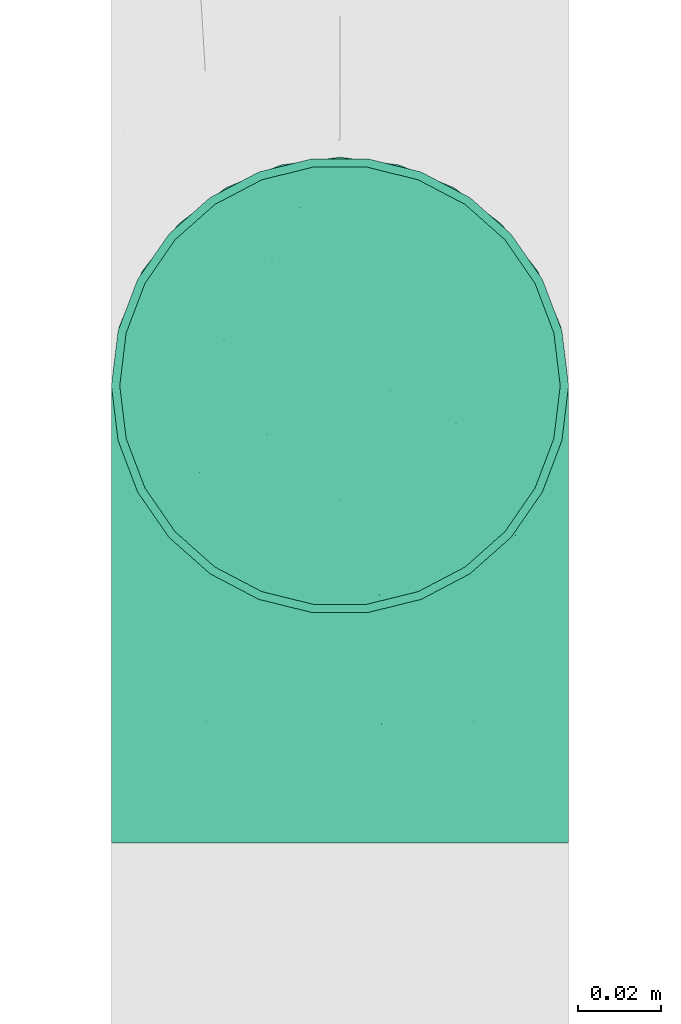
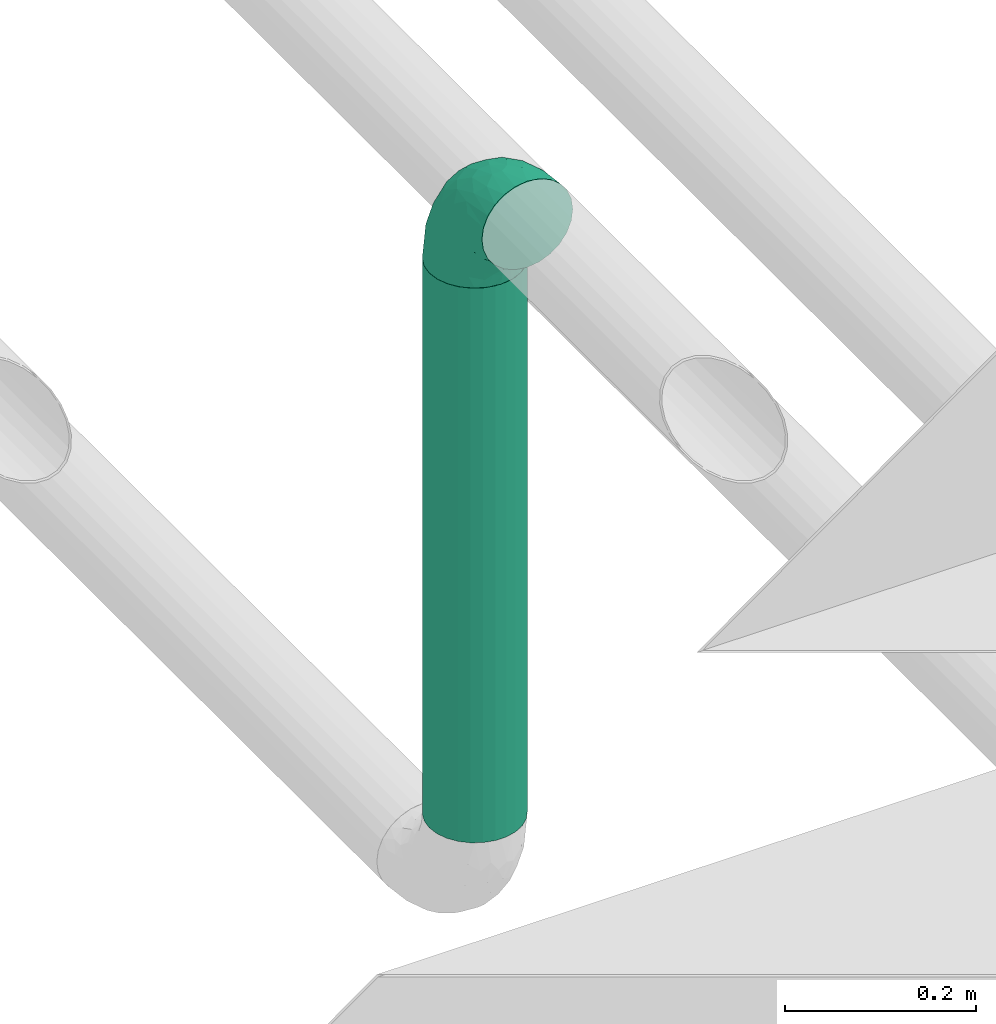
# One storey, part 43 of 91: 1 flow fitting, 1 flow segment.
"""IFC2X3 building model written with IfcOpenShell, lengths in millimetres."""

import ifcopenshell
import ifcopenshell.guid

model = None  # the IFC model being written
_history = None  # IfcOwnerHistory: only IFC2X3 demands one
_inside = {}  # id of a spatial element -> (the spatial element, [elements in it])
_under = {}  # id of a project, library or spatial element -> (it, [spatial elements below it])
_declared = {}  # id of a project -> (the project, [libraries it declares])
_typed = {}  # id of a type object -> (the type object, [elements of that type])
_made_of = {}  # id of a material, layer set ... -> (it, [elements and type objects made of it])


def new_model(schema):
    """Start an empty IFC model of exactly this schema.

    Asked for "IFC4X3", IfcOpenShell would pick the latest addendum, in which some entities
    have other attributes; the version numbers below select the first issue.
    IFC2X3 requires an IfcOwnerHistory on every rooted entity: one is made here for all.
    """
    global model, _history
    if schema == "IFC4X3":
        model = ifcopenshell.file(schema_version=(4, 3, 0, 0))
    else:
        model = ifcopenshell.file(schema=schema)
    _inside.clear()
    _under.clear()
    _declared.clear()
    _typed.clear()
    _made_of.clear()
    _history = None
    if model.schema == "IFC2X3":
        org = make("IfcOrganization", Name="unknown")
        user = make(
            "IfcPersonAndOrganization",
            ThePerson=make("IfcPerson", FamilyName="unknown"),
            TheOrganization=org,
        )
        app = make(
            "IfcApplication",
            ApplicationDeveloper=org,
            Version="unknown",
            ApplicationFullName="unknown",
            ApplicationIdentifier="unknown",
        )
        _history = make(
            "IfcOwnerHistory",
            OwningUser=user,
            OwningApplication=app,
            ChangeAction="ADDED",
            CreationDate=0,
        )
    return model


def make(cls, **values):
    """One entity of the class cls with the attributes given. An attribute that is None is left unset."""
    return model.create_entity(
        cls, **{name: value for name, value in values.items() if value is not None}
    )


def entity(cls, *values):
    """Any entity or typed value of the class cls, its attributes in the order of the schema. None: left unset."""
    e = model.create_entity(cls)
    for i, value in enumerate(values):
        if value is not None:
            e[i] = value
    return e


def rooted(cls, **values):
    """An entity with a GlobalId (a new one), such as an element, a storey or a relation."""
    return make(cls, GlobalId=ifcopenshell.guid.new(), OwnerHistory=_history, **values)


def si_unit(unit_type, name, prefix=None):
    """IfcSIUnit, for example si_unit("LENGTHUNIT", "METRE", prefix="MILLI")."""
    return make("IfcSIUnit", UnitType=unit_type, Prefix=prefix, Name=name)


def converted_unit(unit_type, name, factor, base, dimensions=None, offset=None):
    """IfcConversionBasedUnit, such as the inch: factor (a typed value) times the base unit."""
    return make(
        "IfcConversionBasedUnit"
        if offset is None
        else "IfcConversionBasedUnitWithOffset",
        ConversionOffset=offset,
        Dimensions=None
        if dimensions is None
        else entity("IfcDimensionalExponents", *dimensions),
        UnitType=unit_type,
        Name=name,
        ConversionFactor=make(
            "IfcMeasureWithUnit", ValueComponent=factor, UnitComponent=base
        ),
    )


def derived_unit(unit_type, elements):
    """IfcDerivedUnit: a product of units, each with its exponent."""
    return make(
        "IfcDerivedUnit",
        Elements=[
            make("IfcDerivedUnitElement", Unit=unit, Exponent=power)
            for unit, power in elements
        ],
        UnitType=unit_type,
    )


def assignment(units):
    """IfcUnitAssignment: the units of a project."""
    return None if units is None else make("IfcUnitAssignment", Units=units)


def point(xyz):
    """IfcCartesianPoint."""
    return None if xyz is None else make("IfcCartesianPoint", Coordinates=xyz)


def direction(xyz):
    """IfcDirection."""
    return None if xyz is None else make("IfcDirection", DirectionRatios=xyz)


def frame(location, z_axis=None, x_axis=None):
    """IfcAxis2Placement3D, a coordinate frame: its origin and axes. An axis left out is left unset."""
    return make(
        "IfcAxis2Placement3D",
        Location=point(location),
        Axis=direction(z_axis),
        RefDirection=direction(x_axis),
    )


def frame_2d(location, x_axis=None):
    """IfcAxis2Placement2D, a coordinate frame in the plane: its origin and x axis."""
    return make(
        "IfcAxis2Placement2D", Location=point(location), RefDirection=direction(x_axis)
    )


def origin_with_axes():
    """The frame at (0, 0, 0) with the z axis (0, 0, 1) and the x axis (1, 0, 0) written out."""
    return frame((0.0, 0.0, 0.0), z_axis=(0.0, 0.0, 1.0), x_axis=(1.0, 0.0, 0.0))


def origin_2d_with_axis():
    """The frame at (0, 0) in the plane with the x axis (1, 0) written out."""
    return frame_2d((0.0, 0.0), x_axis=(1.0, 0.0))


def place(relative_to, where):
    """IfcLocalPlacement: puts the frame where relative to a parent placement (None: the world)."""
    return make(
        "IfcLocalPlacement", PlacementRelTo=relative_to, RelativePlacement=where
    )


def context(
    kind, dimensions, precision=None, world=None, true_north=None, identifier=None
):
    """IfcGeometricRepresentationContext, for example the 3D "Model" context."""
    return make(
        "IfcGeometricRepresentationContext",
        ContextIdentifier=identifier,
        ContextType=kind,
        CoordinateSpaceDimension=dimensions,
        Precision=precision,
        WorldCoordinateSystem=world,
        TrueNorth=true_north,
    )


def subcontext(parent, identifier, kind, view, scale=None):
    """IfcGeometricRepresentationSubContext, for example "Body" below "Model"."""
    return make(
        "IfcGeometricRepresentationSubContext",
        ContextIdentifier=identifier,
        ContextType=kind,
        ParentContext=parent,
        TargetScale=scale,
        TargetView=view,
    )


def project(units=None, contexts=None):
    """IfcProject with its units and contexts."""
    return rooted(
        "IfcProject",
        Name="project",
        RepresentationContexts=contexts,
        UnitsInContext=assignment(units),
    )


def spatial(cls, under=None, at=None, **own):
    """A site, building, storey or space (cls), placed at a placement, below another one or the project."""
    s = rooted(cls, ObjectPlacement=at, **own)
    if under is not None:
        _under.setdefault(under.id(), (under, []))[1].append(s)
    return s


def profile(cls, at=None, kind="AREA", **sizes):
    """A parametric profile (cls). Its sizes go by their IFC names, for example OverallWidth=200.0."""
    return make(cls, ProfileType=kind, Position=at, **sizes)


def hollow_circle(**sizes):
    """IfcCircleHollowProfileDef."""
    return profile("IfcCircleHollowProfileDef", **sizes)


def extrude(swept, where, along, depth):
    """IfcExtrudedAreaSolid: the profile swept, set in the frame where, extruded along a direction by depth."""
    return make(
        "IfcExtrudedAreaSolid",
        SweptArea=swept,
        Position=where,
        ExtrudedDirection=direction(along),
        Depth=depth,
    )


def faces_of(points, faces, orient=None, outer=None):
    """IfcFace entities. A face is a list of loops; a loop is a list of indices into points, from 0.

    orient and outer hold one flag for each loop. By default every Orientation is true, the
    first loop of a face is its IfcFaceOuterBound and the others are IfcFaceBound.
    """
    made = []
    for i, loops in enumerate(faces):
        bounds = []
        for j, loop in enumerate(loops):
            is_outer = j == 0 if outer is None else outer[i][j]
            bounds.append(
                make(
                    "IfcFaceOuterBound" if is_outer else "IfcFaceBound",
                    Bound=make("IfcPolyLoop", Polygon=[points[k] for k in loop]),
                    Orientation=True if orient is None else orient[i][j],
                )
            )
        made.append(make("IfcFace", Bounds=bounds))
    return made


def open_shell(faces, orient=None, outer=None):
    """The faces of one IfcOpenShell. surface_model builds it on its shared points."""
    return ("IfcOpenShell", faces, orient, outer)


def surface_model(cls, points, shells):
    """IfcFaceBasedSurfaceModel or IfcShellBasedSurfaceModel (cls): surfaces that need not close."""
    shared = [point(p) for p in points]
    made = [make(c, CfsFaces=faces_of(shared, fs, o, b)) for c, fs, o, b in shells]
    if cls == "IfcFaceBasedSurfaceModel":
        return make(cls, FbsmFaces=made)
    return make(cls, SbsmBoundary=made)


def shape(context_of_items, identifier, shape_type, items):
    """IfcShapeRepresentation: the items that make up one representation, for example the "Body"."""
    return make(
        "IfcShapeRepresentation",
        ContextOfItems=context_of_items,
        RepresentationIdentifier=identifier,
        RepresentationType=shape_type,
        Items=items,
    )


def source(mapping_origin, context_of_items, identifier, shape_type, items):
    """IfcRepresentationMap: a shape defined once, which mapped items show again and again."""
    return make(
        "IfcRepresentationMap",
        MappingOrigin=mapping_origin,
        MappedRepresentation=shape(context_of_items, identifier, shape_type, items),
    )


def transform(
    local_origin,
    x_axis=None,
    y_axis=None,
    z_axis=None,
    scale=None,
    scale2=None,
    scale3=None,
    uniform=True,
):
    """IfcCartesianTransformationOperator3D, or its non-uniform kind. x_axis, y_axis, z_axis: its Axis1, 2, 3."""
    if uniform:
        return make(
            "IfcCartesianTransformationOperator3D",
            Axis1=direction(x_axis),
            Axis2=direction(y_axis),
            LocalOrigin=point(local_origin),
            Scale=scale,
            Axis3=direction(z_axis),
        )
    return make(
        "IfcCartesianTransformationOperator3DnonUniform",
        Axis1=direction(x_axis),
        Axis2=direction(y_axis),
        LocalOrigin=point(local_origin),
        Scale=scale,
        Axis3=direction(z_axis),
        Scale2=scale2,
        Scale3=scale3,
    )


def mapped(mapping_source, mapping_target):
    """IfcMappedItem: shows the shape of a source again, moved by a transform."""
    return make(
        "IfcMappedItem", MappingSource=mapping_source, MappingTarget=mapping_target
    )


def material(Name=None, Category=None):
    """IfcMaterial."""
    return make("IfcMaterial", Name=Name, Category=Category)


def layer(
    of_material, thickness, ventilated=None, Name=None, Category=None, Priority=None
):
    """IfcMaterialLayer: one layer of a wall or slab, of a material (None: an air gap)."""
    return make(
        "IfcMaterialLayer",
        Material=of_material,
        LayerThickness=thickness,
        IsVentilated=ventilated,
        Name=Name,
        Category=Category,
        Priority=Priority,
    )


def layer_set(layers, Name=None):
    """IfcMaterialLayerSet."""
    return make("IfcMaterialLayerSet", MaterialLayers=layers, LayerSetName=Name)


def layer_usage(for_layer_set, set_direction, sense, offset, extent=None):
    """IfcMaterialLayerSetUsage: how a layer set lies in its element."""
    return make(
        "IfcMaterialLayerSetUsage",
        ForLayerSet=for_layer_set,
        LayerSetDirection=set_direction,
        DirectionSense=sense,
        OffsetFromReferenceLine=offset,
        ReferenceExtent=extent,
    )


def made_of(thing, what):
    """Note that an element or type object is made of a material, layer set ...; save() writes the relation."""
    if what is not None:
        _made_of.setdefault(what.id(), (what, []))[1].append(thing)
    return thing


def type_object(cls, material=None, **own):
    """A type object (cls), such as IfcWallType, which elements share."""
    return made_of(rooted(cls, **own), material)


def element(
    cls,
    number,
    at=None,
    inside=None,
    cuts=None,
    type_object=None,
    material=None,
    context=None,
    identifier="Body",
    shape_type=None,
    held_by="IfcProductDefinitionShape",
    body=None,
    shapes=None,
    **own,
):
    """One element of the class cls, such as IfcWall. Its Tag is "e" and its number.

    at: its placement. inside: the storey or other place that contains it. cuts: it is an
    opening in that element (IfcRelVoidsElement). A single representation is given by context,
    identifier, shape_type and body (its items); several are given by shapes. held_by: the class
    of the entity that holds the representations. save() writes the other relations.
    """
    e = rooted(cls, Tag="e%d" % number, ObjectPlacement=at, **own)
    if body is not None:
        shapes = [shape(context, identifier, shape_type, body)]
    if shapes is not None:
        e.Representation = make(held_by, Representations=shapes)
    if inside is not None:
        _inside.setdefault(inside.id(), (inside, []))[1].append(e)
    if cuts is not None:
        rooted(
            "IfcRelVoidsElement", RelatingBuildingElement=cuts, RelatedOpeningElement=e
        )
    if type_object is not None:
        _typed.setdefault(type_object.id(), (type_object, []))[1].append(e)
    return made_of(e, material)


def aggregate(whole, parts):
    """IfcRelAggregates: a whole, such as a stair, and the parts it consists of."""
    return rooted("IfcRelAggregates", RelatingObject=whole, RelatedObjects=parts)


def save(model, path):
    """Write the relations noted so far, then the file.

    IfcRelAggregates (storeys below a building ...), IfcRelContainedInSpatialStructure (elements
    in a storey), IfcRelDefinesByType, IfcRelAssociatesMaterial and IfcRelDeclares: one each for
    every whole, place, type object, material and project.
    """
    for whole, parts in _under.values():
        aggregate(whole, parts)
    for where, things in _inside.values():
        rooted(
            "IfcRelContainedInSpatialStructure",
            RelatedElements=things,
            RelatingStructure=where,
        )
    for kind, things in _typed.values():
        rooted("IfcRelDefinesByType", RelatedObjects=things, RelatingType=kind)
    for what, things in _made_of.values():
        rooted("IfcRelAssociatesMaterial", RelatedObjects=things, RelatingMaterial=what)
    for by, libraries in _declared.values():
        rooted("IfcRelDeclares", RelatingContext=by, RelatedDefinitions=libraries)
    model.write(path)


model = new_model("IFC2X3")

# Units and contexts
model_context = context("Model", 3, precision=1e-05, world=origin_with_axes(), true_north=direction((0.0, 1.0)))
body_context = subcontext(model_context, "Body", "Model", "MODEL_VIEW")
ifc_project = project(units=[si_unit("AREAUNIT", "SQUARE_METRE"), si_unit("VOLUMEUNIT", "CUBIC_METRE", prefix="DECI"), si_unit("TIMEUNIT", "SECOND"), si_unit("THERMODYNAMICTEMPERATUREUNIT", "DEGREE_CELSIUS"), si_unit("PRESSUREUNIT", "PASCAL"), si_unit("MASSUNIT", "GRAM", prefix="KILO"), si_unit("LENGTHUNIT", "METRE", prefix="MILLI"), si_unit("POWERUNIT", "WATT"), si_unit("ELECTRICCURRENTUNIT", "AMPERE"), si_unit("ELECTRICVOLTAGEUNIT", "VOLT"), derived_unit("VOLUMETRICFLOWRATEUNIT", [(si_unit("VOLUMEUNIT", "CUBIC_METRE", prefix="DECI"), 1), (si_unit("TIMEUNIT", "SECOND"), -1)]), derived_unit("LINEARVELOCITYUNIT", [(si_unit("LENGTHUNIT", "METRE"), 1), (si_unit("TIMEUNIT", "SECOND"), -1)]), derived_unit("MASSDENSITYUNIT", [(si_unit("MASSUNIT", "GRAM", prefix="KILO"), 1), (si_unit("VOLUMEUNIT", "CUBIC_METRE"), -1)]), converted_unit("PLANEANGLEUNIT", "DEGREE", entity("IfcRatioMeasure", 0.01745), si_unit("PLANEANGLEUNIT", "RADIAN"), dimensions=[0, 0, 0, 0, 0, 0, 0])], contexts=[model_context])

# Site, building, storey
site_placement = place(None, origin_with_axes())
site = spatial("IfcSite", under=ifc_project, at=site_placement, CompositionType="ELEMENT")
building_placement = place(site_placement, origin_with_axes())
building = spatial("IfcBuilding", under=site, at=building_placement, Name="mc-building", CompositionType="ELEMENT")
storey_placement = place(building_placement, frame((0.0, 0.0, 8700.0), z_axis=(0.0, 0.0, 1.0), x_axis=(1.0, 0.0, 0.0)))
storey = spatial("IfcBuildingStorey", under=building, at=storey_placement, CompositionType="ELEMENT", Elevation=8700.0)

# Flow segment
ifc_material = material(Name="FZ1")
ifc_layer = layer(ifc_material, 0.0)
ifc_layer_set = layer_set([ifc_layer], Name="FZ1")
ifc_layer_usage = layer_usage(ifc_layer_set, "AXIS1", "POSITIVE", 0.0)
duct_segment_type = type_object("IfcDuctSegmentType", PredefinedType="RIGIDSEGMENT")
shared_shape_1 = source(origin_with_axes(), body_context, "Body", "SweptSolid", [
    extrude(hollow_circle(Radius=55.0, WallThickness=2.0, at=origin_2d_with_axis()), frame((0.0, 0.0, 0.0), z_axis=(1.0, 0.0, 0.0), x_axis=(0.0, 1.0, 0.0)), (0.0, 0.0, 1.0), 709.0),
])
flow_segment_placement = place(storey_placement, frame((11458.64544, 8918.87648, 1234.0), z_axis=(0.0, 1.0, 0.0), x_axis=(0.0, 0.0, -1.0)))
element("IfcFlowSegment", 1, at=flow_segment_placement, inside=storey, type_object=duct_segment_type, material=ifc_layer_usage, context=body_context, shape_type="MappedRepresentation", body=[
    mapped(shared_shape_1, transform((0.0, 0.0, 0.0), scale=1.0)),
])

# Flow fitting
duct_fitting_type = type_object("IfcDuctFittingType", Name="BU", PredefinedType="BEND")
shared_shape_2 = source(origin_with_axes(), body_context, "Body", "SurfaceModel", [
    surface_model("IfcShellBasedSurfaceModel", [(-110.0, 0.0, -55.0), (-110.0, -14.23505, -53.12592), (-110.0, 14.23505, -53.12592), (-110.0, 53.12592, 14.23505), (-110.0, 27.5, -47.63139), (-110.0, 38.89087, -38.89087), (-110.0, -55.0, 0.0), (-110.0, -53.12592, 14.23505), (-110.0, -38.89087, -38.89087), (-110.0, -27.5, -47.63139), (-110.0, -53.12592, -14.23505), (-110.0, -47.63139, -27.5), (-110.0, -14.23505, 53.12592), (-110.0, 14.23505, 53.12592), (-110.0, 27.5, 47.63139), (-110.0, -47.63139, 27.5), (-110.0, -38.89087, 38.89087), (-110.0, -27.5, 47.63139), (-110.0, 0.0, 55.0), (-110.0, 55.0, 0.0), (-110.0, 53.12592, -14.23505), (-110.0, 47.63139, -27.5), (-110.0, 47.63139, 27.5), (-110.0, 38.89087, 38.89087), (-14.23505, 110.0, -53.12592), (-55.0, 110.0, 0.0), (0.0, 110.0, -55.0), (-27.5, 110.0, -47.63139), (-38.89087, 110.0, -38.89087), (-47.63139, 110.0, -27.5), (38.89087, 110.0, -38.89087), (53.12592, 110.0, 14.23505), (27.5, 110.0, -47.63139), (14.23505, 110.0, -53.12592), (47.63139, 110.0, -27.5), (53.12592, 110.0, -14.23505), (55.0, 110.0, 0.0), (-53.12592, 110.0, -14.23505), (-53.12592, 110.0, 14.23505), (-47.63139, 110.0, 27.5), (-38.89087, 110.0, 38.89087), (-27.5, 110.0, 47.63139), (0.0, 110.0, 55.0), (-14.23505, 110.0, 53.12592), (38.89087, 110.0, 38.89087), (47.63139, 110.0, 27.5), (27.5, 110.0, 47.63139), (14.23505, 110.0, 53.12592), (-64.21732, 48.68956, 43.63444), (-76.6405, 38.18013, 45.55988), (-60.44912, 32.56953, 51.94617), (-76.00813, 5.38378, 55.0), (-90.15553, 11.94394, 54.09138), (-78.5998, 26.77405, 50.81338), (-70.18771, 18.55163, 54.03432), (-75.55424, 54.2118, 32.41257), (-93.27622, 45.77614, 33.48188), (-96.12334, 22.13664, 50.81337), (-21.00813, 45.34362, 55.0), (-18.36258, 70.48427, 54.04484), (-32.04182, 59.64019, 52.24446), (-63.88653, 74.77858, 17.99134), (-74.66383, 63.08407, 19.92123), (-63.60674, 66.07878, 29.97482), (-99.597, 52.72185, 18.52927), (-93.11138, 56.59448, 10.50359), (-98.21577, 57.34403, 0.0), (-53.42855, 92.60092, 21.04759), (-88.54852, 54.8376, 21.04759), (-11.86161, 90.23965, 54.10313), (-5.38378, 76.00813, 55.0), (-57.34403, 98.21577, 0.0), (-56.64619, 93.12774, 10.22088), (-45.34362, 21.00813, 55.0), (-44.60838, 44.60838, 52.13415), (-92.68484, 35.46673, 43.63443), (-22.25266, 95.40765, 50.81337), (-35.97783, 90.61597, 43.63443), (-43.70931, 69.58671, 44.47149), (-27.23711, 77.39884, 50.81337), (-57.2828, 79.3123, 24.9774), (-58.67786, 84.31125, 16.04456), (-82.93277, 60.36161, 12.91784), (-49.88337, 54.51816, 47.224), (-74.57753, 66.83759, 9.55742), (-45.35812, 94.97281, 33.48188), (-59.18663, 88.95241, 0.0), (-51.517, 78.6292, 33.48188), (-65.14788, 80.03077, 0.0), (-56.45322, 62.06476, 39.63545), (-88.95241, 59.18663, 0.0), (-71.10913, 71.10913, 0.0), (-80.03077, 65.14788, 0.0), (-94.9309, 45.36788, -33.48188), (-93.11358, 56.60141, -10.46614), (-99.64997, 52.79499, -18.30015), (-90.20425, 36.08686, -43.63443), (-79.99933, 46.56772, -37.92748), (-76.00813, 5.38378, -55.0), (-72.75364, 19.68651, -53.60527), (-45.34362, 21.00813, -55.0), (-21.91957, 65.12078, -53.85897), (-5.38378, 76.00813, -55.0), (-21.00813, 45.34362, -55.0), (-35.41876, 92.89265, -43.63443), (-91.10309, 11.02766, -54.21832), (-45.77614, 93.27622, -33.48188), (-90.50474, 23.21022, -50.81337), (-70.92854, 33.31794, -49.51754), (-78.52933, 63.35627, -11.73997), (-24.91508, 84.05606, -50.81337), (-88.78941, 54.74452, -21.04759), (-69.59921, 57.34866, -33.48187), (-73.36422, 62.46673, -22.94182), (-63.49062, 67.59111, -28.46929), (-56.59448, 93.11138, -10.50359), (-54.8376, 88.54852, -21.04759), (-54.10679, 75.85581, -32.31867), (-57.75956, 31.09612, -52.80882), (-52.72185, 99.597, -18.52927), (-12.62913, 89.46304, -53.99097), (-34.46825, 66.46123, -50.04329), (-43.9837, 43.9837, -52.42279), (-65.78527, 72.58348, -17.68796), (-70.34468, 43.65295, -44.21951), (-57.47001, 51.99467, -44.91465), (-60.72547, 82.29174, -12.88567), (-42.34915, 74.24548, -43.63444), (-57.25194, 63.5016, -38.08211), (-80.95344, 53.56991, -29.32027), (-52.32891, 4.55257, -54.0482), (32.52942, 47.13398, -30.48571), (14.88266, 20.92917, -33.7947), (14.95561, 36.05775, -42.26543), (30.24048, 70.09027, -41.7461), (19.3559, 65.35825, -48.00507), (-70.35075, -46.44478, -19.5952), (-47.13398, -32.52942, -30.48571), (-28.49299, -30.5778, -16.4009), (-4.55257, 52.32891, -54.0482), (-22.4954, 22.4954, -53.25347), (-75.47368, -11.22546, -52.60718), (-81.32209, -51.5606, -9.98467), (-80.81763, -41.84862, -32.14655), (-70.09027, -30.24048, -41.7461), (-36.05774, -14.95561, -42.26543), (-9.15831, -10.852, -27.8997), (-65.35825, -19.3559, -48.00507), (11.22546, 75.47368, -52.60718), (3.94376, 43.9333, -50.53315), (-13.39742, 13.39743, -48.13058), (-43.9333, -3.94376, -50.53315), (49.37776, 67.29486, 0.0), (41.8609, 47.82256, -9.92641), (50.20582, 74.51695, -9.9731), (18.93131, 11.7156, -17.56239), (-27.5, -32.89419, 0.0), (-1.23348, -12.25375, -12.18106), (41.84862, 80.81763, -32.14655), (35.70604, 41.31408, -20.38235), (46.44478, 70.35075, -19.5952), (32.89419, 27.5, 0.0), (6.67262, -6.67262, 0.0), (-67.29486, -49.37776, 0.0), (-50.36265, -42.95545, -9.51562), (-5.47251, 5.47251, -39.92906), (-70.35075, -46.44478, 19.5952), (-74.51695, -50.20582, 9.9731), (-41.31407, -35.70604, 20.38235), (-47.13398, -32.52942, 30.48571), (-80.81763, -41.84862, 32.14655), (-4.55257, 52.32891, 54.0482), (11.22546, 75.47368, 52.60718), (-43.9333, -3.94376, 50.53315), (-65.35825, -19.3559, 48.00507), (-36.05774, -14.95561, 42.26543), (-70.09027, -30.24048, 41.7461), (-11.7156, -18.93131, 17.56239), (30.5778, 28.49299, 16.4009), (12.25375, 1.23348, 12.18106), (51.5606, 81.32209, 9.98467), (42.95545, 50.36265, 9.51562), (-75.47368, -11.22546, 52.60718), (-52.32891, 4.55257, 54.0482), (3.94376, 43.9333, 50.53315), (-22.4954, 22.4954, 53.25347), (-13.39742, 13.39743, 48.13058), (10.852, 9.15831, 27.8997), (-20.92916, -14.88266, 33.79469), (-47.82256, -41.8609, 9.92641), (32.52942, 47.13398, 30.48571), (46.44478, 70.35075, 19.5952), (41.84862, 80.81763, 32.14655), (30.24048, 70.09027, 41.7461), (19.3559, 65.35825, 48.00507), (14.95561, 36.05775, 42.26543), (-5.47251, 5.47251, 39.92906)], [open_shell([[[0, 1, 2]], [[2, 3, 4]], [[4, 3, 5]], [[2, 6, 7]], [[8, 6, 9]], [[1, 9, 6]], [[10, 6, 11]], [[8, 11, 6]], [[6, 2, 1]], [[12, 13, 14]], [[15, 2, 7]], [[16, 17, 2]], [[2, 17, 12]], [[12, 18, 13]], [[19, 20, 3]], [[5, 3, 21]], [[20, 21, 3]], [[22, 3, 2]], [[23, 22, 2]], [[12, 14, 2]], [[2, 14, 23]], [[15, 16, 2]], [[24, 25, 26]], [[27, 25, 24]], [[25, 28, 29]], [[28, 25, 27]], [[30, 26, 31]], [[26, 30, 32]], [[32, 33, 26]], [[34, 31, 35]], [[31, 34, 30]], [[35, 31, 36]], [[29, 37, 25]], [[38, 39, 26]], [[39, 40, 26]], [[41, 42, 40]], [[42, 26, 40]], [[42, 41, 43]], [[26, 44, 45]], [[31, 26, 45]], [[26, 46, 44]], [[47, 46, 26]], [[42, 47, 26]], [[25, 38, 26]], [[48, 49, 50]], [[18, 51, 52]], [[53, 54, 50]], [[55, 56, 49]], [[56, 22, 23]], [[13, 57, 14]], [[58, 59, 60]], [[61, 62, 63]], [[3, 64, 65]], [[53, 52, 54]], [[3, 65, 66]], [[67, 39, 38]], [[56, 68, 64]], [[65, 64, 68]], [[69, 59, 70]], [[38, 71, 72]], [[73, 58, 74]], [[75, 49, 56]], [[76, 69, 43]], [[53, 57, 52]], [[77, 78, 79]], [[41, 76, 43]], [[43, 69, 42]], [[55, 68, 56]], [[23, 14, 75]], [[76, 77, 79]], [[80, 67, 81]], [[62, 82, 68]], [[60, 78, 83]], [[62, 84, 82]], [[85, 77, 40]], [[81, 67, 72]], [[86, 72, 71]], [[87, 85, 67]], [[61, 81, 88]], [[77, 41, 40]], [[78, 77, 87]], [[23, 75, 56]], [[83, 89, 48]], [[85, 40, 39]], [[62, 68, 55]], [[89, 87, 63]], [[83, 48, 50]], [[57, 75, 14]], [[49, 75, 53]], [[67, 85, 39]], [[87, 77, 85]], [[63, 62, 55]], [[89, 55, 48]], [[80, 63, 87]], [[66, 65, 90]], [[66, 19, 3]], [[84, 91, 92]], [[92, 90, 82]], [[65, 82, 90]], [[61, 84, 62]], [[92, 82, 84]], [[68, 82, 65]], [[3, 22, 64]], [[56, 64, 22]], [[38, 25, 71]], [[81, 72, 86]], [[38, 72, 67]], [[91, 61, 88]], [[80, 81, 61]], [[63, 80, 61]], [[67, 80, 87]], [[77, 76, 41]], [[79, 59, 69]], [[79, 69, 76]], [[42, 69, 70]], [[60, 59, 79]], [[58, 70, 59]], [[78, 60, 79]], [[58, 60, 74]], [[52, 57, 13]], [[75, 57, 53]], [[18, 52, 13]], [[52, 51, 54]], [[51, 73, 54]], [[50, 73, 74]], [[73, 50, 54]], [[50, 74, 83]], [[60, 83, 74]], [[89, 83, 78]], [[87, 89, 78]], [[55, 89, 63]], [[50, 49, 53]], [[55, 49, 48]], [[81, 86, 88]], [[91, 84, 61]], [[5, 21, 93]], [[90, 94, 66]], [[20, 94, 95]], [[96, 93, 97]], [[98, 99, 100]], [[96, 4, 5]], [[101, 102, 103]], [[28, 27, 104]], [[2, 105, 0]], [[104, 106, 28]], [[99, 105, 107]], [[108, 107, 96]], [[90, 109, 94]], [[107, 2, 4]], [[20, 66, 94]], [[27, 24, 110]], [[109, 111, 94]], [[112, 113, 114]], [[37, 115, 71]], [[116, 106, 117]], [[99, 118, 100]], [[116, 115, 119]], [[37, 119, 115]], [[24, 120, 110]], [[121, 110, 101]], [[119, 106, 116]], [[101, 110, 120]], [[122, 103, 100]], [[117, 123, 116]], [[124, 125, 108]], [[115, 116, 126]], [[106, 29, 28]], [[26, 102, 120]], [[127, 104, 110]], [[97, 124, 96]], [[125, 122, 118]], [[128, 127, 125]], [[96, 5, 93]], [[115, 126, 86]], [[117, 106, 127]], [[111, 113, 129]], [[95, 93, 21]], [[97, 129, 112]], [[110, 104, 27]], [[106, 104, 127]], [[96, 107, 4]], [[99, 107, 108]], [[99, 108, 118]], [[105, 99, 98]], [[112, 114, 128]], [[121, 125, 127]], [[20, 19, 66]], [[109, 90, 92]], [[94, 111, 95]], [[91, 123, 109]], [[129, 113, 112]], [[93, 95, 111]], [[21, 20, 95]], [[71, 115, 86]], [[71, 25, 37]], [[123, 91, 88]], [[126, 116, 123]], [[123, 88, 126]], [[86, 126, 88]], [[37, 29, 119]], [[106, 119, 29]], [[129, 93, 111]], [[124, 112, 125]], [[0, 105, 98]], [[107, 105, 2]], [[125, 118, 108]], [[100, 118, 122]], [[93, 129, 97]], [[113, 111, 109]], [[109, 123, 113]], [[114, 123, 117]], [[123, 114, 113]], [[128, 114, 117]], [[127, 128, 117]], [[112, 128, 125]], [[103, 122, 101]], [[110, 121, 127]], [[101, 122, 121]], [[125, 121, 122]], [[26, 120, 24]], [[101, 120, 102]], [[96, 124, 108]], [[92, 91, 109]], [[112, 124, 97]], [[100, 130, 98]], [[131, 132, 133]], [[32, 134, 135]], [[136, 137, 138]], [[139, 140, 103]], [[98, 141, 0]], [[142, 10, 136]], [[143, 144, 137]], [[6, 10, 142]], [[137, 145, 146]], [[144, 147, 145]], [[143, 136, 11]], [[11, 136, 10]], [[8, 143, 11]], [[148, 149, 139]], [[8, 9, 144]], [[9, 1, 147]], [[130, 141, 98]], [[103, 140, 100]], [[148, 135, 149]], [[150, 151, 140]], [[152, 153, 154]], [[130, 140, 151]], [[148, 26, 33]], [[147, 1, 141]], [[155, 146, 132]], [[156, 138, 157]], [[134, 30, 158]], [[150, 140, 149]], [[158, 30, 34]], [[30, 134, 32]], [[153, 159, 160]], [[131, 160, 159]], [[144, 145, 137]], [[36, 152, 154]], [[146, 138, 137]], [[155, 161, 162]], [[158, 160, 131]], [[133, 149, 135]], [[156, 163, 164]], [[163, 142, 164]], [[139, 103, 102]], [[153, 152, 161]], [[34, 35, 160]], [[162, 157, 155]], [[132, 165, 133]], [[157, 146, 155]], [[140, 130, 100]], [[141, 130, 151]], [[141, 151, 147]], [[141, 1, 0]], [[102, 26, 148]], [[140, 139, 149]], [[102, 148, 139]], [[135, 33, 32]], [[151, 150, 145]], [[9, 147, 144]], [[151, 145, 147]], [[145, 165, 146]], [[135, 148, 33]], [[133, 135, 134]], [[131, 133, 134]], [[133, 165, 150]], [[133, 150, 149]], [[145, 150, 165]], [[132, 131, 159]], [[146, 165, 132]], [[160, 158, 34]], [[134, 158, 131]], [[144, 143, 8]], [[136, 143, 137]], [[155, 153, 161]], [[154, 153, 160]], [[153, 155, 159]], [[132, 159, 155]], [[160, 35, 154]], [[36, 154, 35]], [[164, 136, 138]], [[6, 142, 163]], [[136, 164, 142]], [[156, 164, 138]], [[156, 157, 162]], [[146, 157, 138]], [[15, 7, 166]], [[6, 163, 167]], [[168, 169, 166]], [[166, 169, 170]], [[171, 172, 70]], [[173, 174, 175]], [[17, 176, 174]], [[177, 156, 162]], [[176, 16, 170]], [[170, 16, 15]], [[161, 178, 179]], [[152, 180, 181]], [[182, 173, 183]], [[18, 12, 182]], [[184, 185, 186]], [[183, 185, 73]], [[183, 73, 51]], [[177, 187, 188]], [[189, 168, 166]], [[187, 178, 190]], [[16, 176, 17]], [[161, 152, 181]], [[45, 191, 31]], [[45, 44, 192]], [[192, 191, 45]], [[180, 36, 31]], [[193, 194, 195]], [[46, 47, 194]], [[193, 195, 190]], [[193, 44, 46]], [[172, 42, 70]], [[185, 58, 73]], [[189, 163, 156]], [[163, 189, 167]], [[70, 58, 171]], [[184, 171, 185]], [[169, 188, 175]], [[180, 31, 191]], [[192, 193, 190]], [[191, 190, 178]], [[182, 174, 173]], [[194, 47, 172]], [[190, 195, 187]], [[186, 185, 173]], [[162, 179, 177]], [[188, 196, 175]], [[179, 187, 177]], [[185, 171, 58]], [[172, 171, 184]], [[172, 184, 194]], [[172, 47, 42]], [[51, 18, 182]], [[185, 183, 173]], [[51, 182, 183]], [[174, 12, 17]], [[184, 186, 195]], [[46, 194, 193]], [[184, 195, 194]], [[195, 196, 187]], [[174, 182, 12]], [[175, 174, 176]], [[169, 175, 176]], [[175, 196, 186]], [[175, 186, 173]], [[195, 186, 196]], [[188, 169, 168]], [[187, 196, 188]], [[166, 170, 15]], [[176, 170, 169]], [[193, 192, 44]], [[191, 192, 190]], [[177, 189, 156]], [[167, 189, 166]], [[189, 177, 168]], [[188, 168, 177]], [[166, 7, 167]], [[6, 167, 7]], [[181, 191, 178]], [[36, 180, 152]], [[191, 181, 180]], [[161, 181, 178]], [[161, 179, 162]], [[187, 179, 178]]])]),
])
flow_fitting_placement = place(storey_placement, frame((11458.64544, 8918.87648, 1344.0), z_axis=(1.0, 0.0, 0.0), x_axis=(0.0, 0.0, 1.0)))
element("IfcFlowFitting", 2, at=flow_fitting_placement, inside=storey, type_object=duct_fitting_type, Name="BU", context=body_context, shape_type="MappedRepresentation", body=[
    mapped(shared_shape_2, transform((0.0, 0.0, 0.0), scale=1.0)),
])

save(model, "model.ifc")
